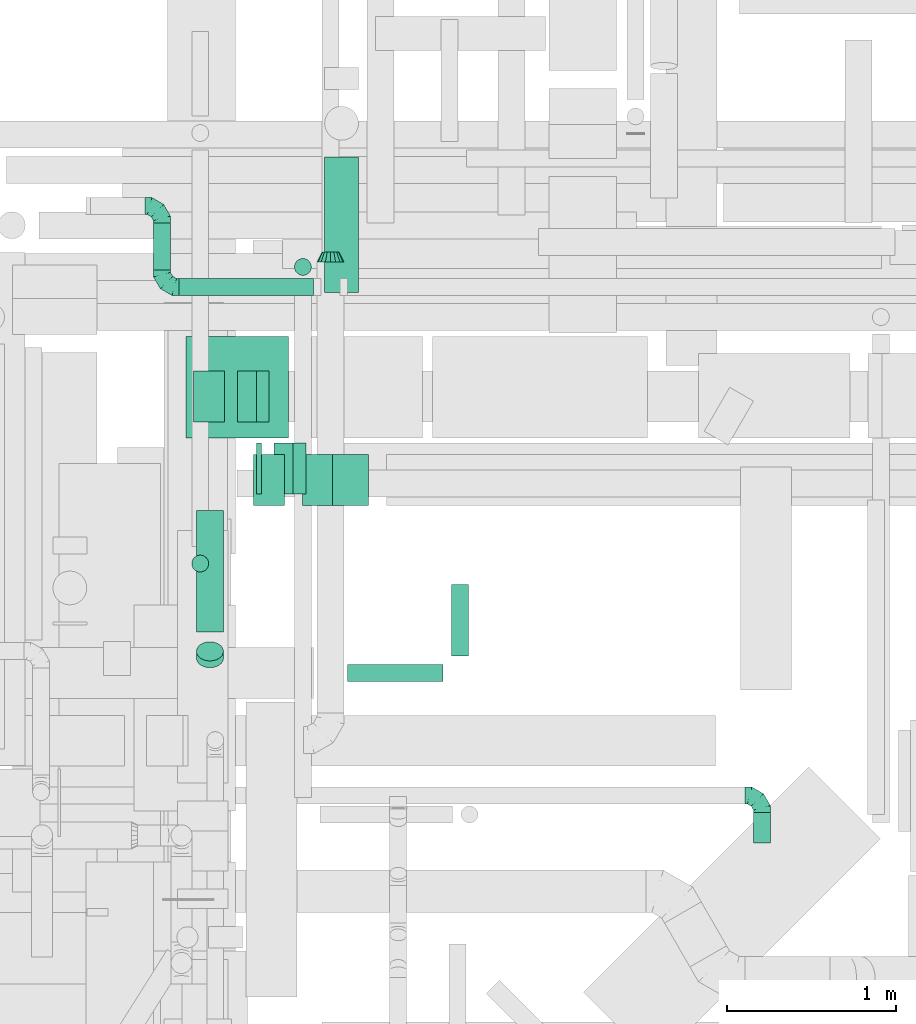
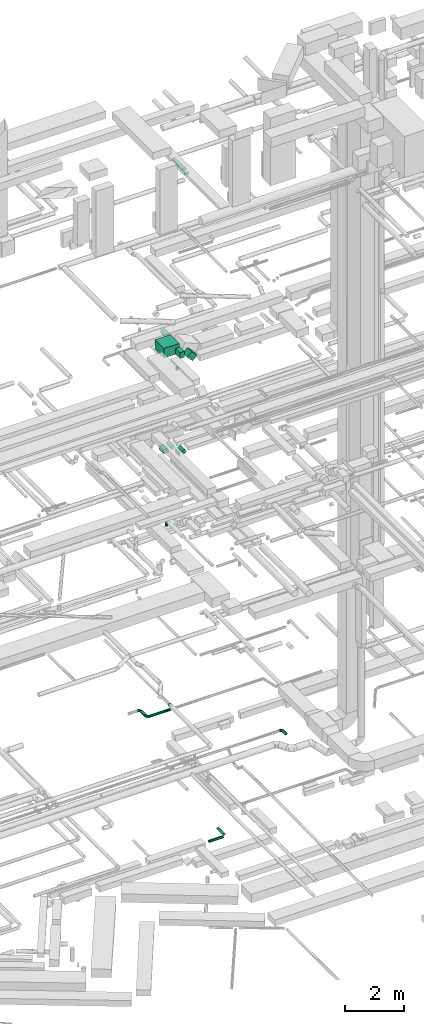
# One storey, part 112 of 337: 17 flow segments, 4 flow fittings.
"""IFC2X3 building model written with IfcOpenShell, lengths in millimetres."""

from ifc_helpers import new_model, entity, si_unit, converted_unit, derived_unit, direction, frame, frame_2d, origin, origin_2d_with_axis, place, context, subcontext, project, spatial, rectangle, circle, extrude, faceted_brep, source, transform, mapped, material, type_object, type_shapes, element, save


model = new_model("IFC2X3")

# Units and contexts
model_context = context("Model", 3, precision=0.01, world=origin(), true_north=direction((6.12303176911189e-17, 1.0)))
body_context = subcontext(model_context, "Body", "Model", "MODEL_VIEW")
ifc_project = project(units=[si_unit("LENGTHUNIT", "METRE", prefix="MILLI"), si_unit("AREAUNIT", "SQUARE_METRE"), si_unit("VOLUMEUNIT", "CUBIC_METRE"), converted_unit("PLANEANGLEUNIT", "DEGREE", entity("IfcRatioMeasure", 0.0174532925199433), si_unit("PLANEANGLEUNIT", "RADIAN"), dimensions=[0, 0, 0, 0, 0, 0, 0]), si_unit("MASSUNIT", "GRAM", prefix="KILO"), derived_unit("MASSDENSITYUNIT", [(si_unit("MASSUNIT", "GRAM", prefix="KILO"), 1), (si_unit("LENGTHUNIT", "METRE"), -3)]), derived_unit("MOMENTOFINERTIAUNIT", [(si_unit("LENGTHUNIT", "METRE"), 4)]), si_unit("TIMEUNIT", "SECOND"), si_unit("FREQUENCYUNIT", "HERTZ"), si_unit("THERMODYNAMICTEMPERATUREUNIT", "DEGREE_CELSIUS"), derived_unit("THERMALTRANSMITTANCEUNIT", [(si_unit("MASSUNIT", "GRAM", prefix="KILO"), 1), (si_unit("THERMODYNAMICTEMPERATUREUNIT", "KELVIN"), -1), (si_unit("TIMEUNIT", "SECOND"), -3)]), derived_unit("VOLUMETRICFLOWRATEUNIT", [(si_unit("LENGTHUNIT", "METRE"), 3), (si_unit("TIMEUNIT", "SECOND"), -1)]), derived_unit("MASSFLOWRATEUNIT", [(si_unit("MASSUNIT", "GRAM", prefix="KILO"), 1), (si_unit("TIMEUNIT", "SECOND"), -1)]), derived_unit("ROTATIONALFREQUENCYUNIT", [(si_unit("TIMEUNIT", "SECOND"), -1)]), si_unit("ELECTRICCURRENTUNIT", "AMPERE"), si_unit("ELECTRICVOLTAGEUNIT", "VOLT"), si_unit("POWERUNIT", "WATT"), si_unit("FORCEUNIT", "NEWTON", prefix="KILO"), si_unit("ILLUMINANCEUNIT", "LUX"), si_unit("LUMINOUSFLUXUNIT", "LUMEN"), si_unit("LUMINOUSINTENSITYUNIT", "CANDELA"), derived_unit("USERDEFINED", [(si_unit("MASSUNIT", "GRAM", prefix="KILO"), -1), (si_unit("LENGTHUNIT", "METRE"), -2), (si_unit("TIMEUNIT", "SECOND"), 3), (si_unit("LUMINOUSFLUXUNIT", "LUMEN"), 1)]), derived_unit("LINEARVELOCITYUNIT", [(si_unit("LENGTHUNIT", "METRE"), 1), (si_unit("TIMEUNIT", "SECOND"), -1)]), si_unit("PRESSUREUNIT", "PASCAL"), derived_unit("USERDEFINED", [(si_unit("LENGTHUNIT", "METRE"), -2), (si_unit("MASSUNIT", "GRAM", prefix="KILO"), 1), (si_unit("TIMEUNIT", "SECOND"), -2)]), derived_unit("LINEARFORCEUNIT", [(si_unit("MASSUNIT", "GRAM", prefix="KILO"), 1), (si_unit("LENGTHUNIT", "METRE"), 1), (si_unit("TIMEUNIT", "SECOND"), -2), (si_unit("LENGTHUNIT", "METRE"), -1)]), derived_unit("PLANARFORCEUNIT", [(si_unit("MASSUNIT", "GRAM", prefix="KILO"), 1), (si_unit("LENGTHUNIT", "METRE"), 1), (si_unit("TIMEUNIT", "SECOND"), -2), (si_unit("LENGTHUNIT", "METRE"), -2)])], contexts=[model_context])

# Site, building, storey
site_placement = place(None, origin())
site = spatial("IfcSite", under=ifc_project, at=site_placement, CompositionType="ELEMENT")
building_placement = place(site_placement, origin())
building = spatial("IfcBuilding", under=site, at=building_placement, CompositionType="ELEMENT")
storey_placement = place(building_placement, origin())
storey = spatial("IfcBuildingStorey", under=building, at=storey_placement, CompositionType="ELEMENT", Elevation=0.0)

# Flow segments
duct_segment_type_1 = type_object("IfcDuctSegmentType", PredefinedType="NOTDEFINED")
flow_segment_1_placement = place(storey_placement, frame((18449.48, 14422.9, 18950.0)))
element("IfcFlowSegment", 1, at=flow_segment_1_placement, inside=storey, type_object=duct_segment_type_1, context=body_context, shape_type="SweptSolid", body=[
    extrude(rectangle(XDim=606.778443805335, YDim=600.0, at=origin_2d_with_axis()), frame((303.39, 300.0, 0.0)), (0.0, 0.0, 1.0), 400.0),
])
flow_segment_2_placement = place(storey_placement, frame((18849.92, 14025.53, 19025.0)))
element("IfcFlowSegment", 2, at=flow_segment_2_placement, inside=storey, type_object=duct_segment_type_1, context=body_context, shape_type="SweptSolid", body=[
    extrude(rectangle(XDim=183.871270347418, YDim=300.000000000001, at=origin_2d_with_axis()), frame((91.94, 150.0, 0.0)), (0.0, 0.0, 1.0), 249.999999999999),
])
flow_segment_3_placement = place(storey_placement, frame((19139.86, 14025.53, 18767.16)))
element("IfcFlowSegment", 3, at=flow_segment_3_placement, inside=storey, type_object=duct_segment_type_1, context=body_context, shape_type="SweptSolid", body=[
    extrude(rectangle(XDim=250.000000000003, YDim=300.000000000001, at=origin_2d_with_axis()), frame((302.3, 150.0, 88.39), z_axis=(-0.707106781186509, 0.0, 0.707106781186587), x_axis=(0.707106781186587, 0.0, 0.707106781186509)), (0.0, 0.0, 1.0), 302.512626584715),
])
flow_segment_4_placement = place(storey_placement, frame((18494.75, 14518.91, 14925.0)))
element("IfcFlowSegment", 4, at=flow_segment_4_placement, inside=storey, type_object=duct_segment_type_1, context=body_context, shape_type="SweptSolid", body=[
    extrude(rectangle(XDim=184.695514085697, YDim=299.999999999999, at=origin_2d_with_axis()), frame((92.35, 150.0, 0.0)), (0.0, 0.0, 1.0), 150.000000000001),
])
flow_segment_5_placement = place(storey_placement, frame((18754.45, 14518.91, 14965.19)))
element("IfcFlowSegment", 5, at=flow_segment_5_placement, inside=storey, type_object=duct_segment_type_1, context=body_context, shape_type="SweptSolid", body=[
    extrude(rectangle(XDim=150.0, YDim=129.422872747523, at=frame_2d((0.0, 0.0), x_axis=(0.0, 1.0))), frame((93.54, 0.0, 97.31), z_axis=(0.0, 1.0, 0.0), x_axis=(0.866025410712589, 0.0, 0.499999988000091)), (0.0, 0.0, 1.0), 300.000000000001),
])
flow_segment_6_placement = place(storey_placement, frame((18866.63, 14093.91, 14925.0)))
element("IfcFlowSegment", 6, at=flow_segment_6_placement, inside=storey, type_object=duct_segment_type_1, context=body_context, shape_type="SweptSolid", body=[
    extrude(rectangle(XDim=30.4263240360212, YDim=300.000000000001, at=origin_2d_with_axis()), frame((15.21, 150.0, 0.0), z_axis=(0.0, 0.0, 1.0), x_axis=(-1.0, 0.0, 0.0)), (0.0, 0.0, 1.0), 150.000000000001),
])
flow_segment_7_placement = place(storey_placement, frame((18972.06, 14093.91, 14965.19)))
element("IfcFlowSegment", 7, at=flow_segment_7_placement, inside=storey, type_object=duct_segment_type_1, context=body_context, shape_type="SweptSolid", body=[
    extrude(rectangle(XDim=149.999999999999, YDim=129.422872747541, at=frame_2d((0.0, 0.0), x_axis=(0.0, 1.0))), frame((93.54, 0.0, 97.31), z_axis=(0.0, 1.0, 0.0), x_axis=(-0.866025410712638, 0.0, -0.499999988000007)), (0.0, 0.0, 1.0), 300.000000000001),
])
duct_segment_type_2 = type_object("IfcDuctSegmentType", PredefinedType="NOTDEFINED")
flow_segment_8_placement = place(storey_placement, frame((19405.55, 12982.48, -601.6)))
element("IfcFlowSegment", 8, at=flow_segment_8_placement, inside=storey, type_object=duct_segment_type_2, context=body_context, shape_type="SweptSolid", body=[
    extrude(circle(Radius=50.0, at=origin_2d_with_axis()), frame((0.0, 51.6, 51.6), z_axis=(1.0, 0.0, 0.0), x_axis=(0.0, -1.0, 0.0)), (0.0, 0.0, 1.0), 563.528786616429),
])
flow_segment_9_placement = place(storey_placement, frame((20017.48, 13134.08, -601.6)))
element("IfcFlowSegment", 9, at=flow_segment_9_placement, inside=storey, type_object=duct_segment_type_2, context=body_context, shape_type="SweptSolid", body=[
    extrude(circle(Radius=50.0, at=origin_2d_with_axis()), frame((51.6, 0.0, 51.6), z_axis=(0.0, 1.0, 0.0), x_axis=(1.0, 0.0, 0.0)), (0.0, 0.0, 1.0), 425.000000000081),
])
flow_segment_10_placement = place(storey_placement, frame((19089.97, 15383.25, 11170.0)))
element("IfcFlowSegment", 10, at=flow_segment_10_placement, inside=storey, type_object=duct_segment_type_2, context=body_context, shape_type="SweptSolid", body=[
    extrude(circle(Radius=50.0, at=origin_2d_with_axis()), frame((51.6, 51.6, 0.0), z_axis=(0.0, 0.0, 1.0), x_axis=(-1.0, 0.0, 0.0)), (0.0, 0.0, 1.0), 129.999999999992),
])
flow_segment_11_placement = place(storey_placement, frame((18408.44, 15264.53, 3548.4)))
element("IfcFlowSegment", 11, at=flow_segment_11_placement, inside=storey, type_object=duct_segment_type_2, context=body_context, shape_type="SweptSolid", body=[
    extrude(circle(Radius=50.0, at=origin_2d_with_axis()), frame((0.0, 51.6, 51.6), z_axis=(1.0, 0.0, 0.0), x_axis=(0.0, -1.0, 0.0)), (0.0, 0.0, 1.0), 796.250000000051),
])
flow_segment_12_placement = place(storey_placement, frame((18256.85, 15416.13, 3548.4)))
element("IfcFlowSegment", 12, at=flow_segment_12_placement, inside=storey, type_object=duct_segment_type_2, context=body_context, shape_type="SweptSolid", body=[
    extrude(circle(Radius=50.0, at=origin_2d_with_axis()), frame((51.6, 0.0, 51.6), z_axis=(0.0, 1.0, 0.0), x_axis=(1.0, 0.0, 0.0)), (0.0, 0.0, 1.0), 278.749999999971),
])
flow_segment_13_placement = place(storey_placement, frame((18482.93, 13629.62, 18900.0)))
element("IfcFlowSegment", 13, at=flow_segment_13_placement, inside=storey, type_object=duct_segment_type_2, context=body_context, shape_type="SweptSolid", body=[
    extrude(circle(Radius=50.0, at=origin_2d_with_axis()), frame((51.6, 51.6, 0.0), z_axis=(0.0, 0.0, 1.0), x_axis=(-1.0, 0.0, 0.0)), (0.0, 0.0, 1.0), 104.999999999976),
])
flow_segment_14_placement = place(storey_placement, frame((19268.68, 15283.92, 18653.4)))
element("IfcFlowSegment", 14, at=flow_segment_14_placement, inside=storey, type_object=duct_segment_type_2, context=body_context, shape_type="SweptSolid", body=[
    extrude(circle(Radius=100.0, at=origin_2d_with_axis()), frame((101.6, 0.0, 101.6), z_axis=(0.0, 1.0, 0.0), x_axis=(-1.0, 0.0, 0.0)), (0.0, 0.0, 1.0), 800.000000000009),
])
flow_segment_15_placement = place(storey_placement, frame((18510.14, 13064.23, 27254.97)))
element("IfcFlowSegment", 15, at=flow_segment_15_placement, inside=storey, type_object=duct_segment_type_2, context=body_context, shape_type="SweptSolid", body=[
    extrude(circle(Radius=80.0, at=origin_2d_with_axis()), frame((81.6, 58.16, 58.16), z_axis=(0.0, 0.707106781186551, 0.707106781186544), x_axis=(1.0, 0.0, 0.0)), (0.0, 0.0, 1.0), 56.5685424949942),
])
flow_segment_16_placement = place(storey_placement, frame((18510.14, 13275.54, 27318.4)))
element("IfcFlowSegment", 16, at=flow_segment_16_placement, inside=storey, type_object=duct_segment_type_2, context=body_context, shape_type="SweptSolid", body=[
    extrude(circle(Radius=80.0, at=origin_2d_with_axis()), frame((81.6, 0.0, 81.6), z_axis=(0.0, 1.0, 0.0), x_axis=(-1.0, 0.0, 0.0)), (0.0, 0.0, 1.0), 719.425830020302),
])
flow_segment_17_placement = place(storey_placement, frame((21803.57, 12030.36, 3598.4)))
element("IfcFlowSegment", 17, at=flow_segment_17_placement, inside=storey, type_object=duct_segment_type_2, context=body_context, shape_type="SweptSolid", body=[
    extrude(circle(Radius=50.0, at=origin_2d_with_axis()), frame((51.6, 0.0, 51.6), z_axis=(0.0, 1.0, 0.0), x_axis=(-1.0, 0.0, 0.0)), (0.0, 0.0, 1.0), 179.999999999994),
])

# Flow fittings
ifc_material = material()
duct_fitting_type_1 = type_object("IfcDuctFittingType", PredefinedType="NOTDEFINED", material=ifc_material)
shared_shape_1 = source(origin(), body_context, "Body", "Brep", [
    faceted_brep([(-100.0, 0.0, -50.0), (-100.0, -12.94, -48.3), (-100.0, -25.0, -43.3), (-100.0, -35.36, -35.36), (-100.0, -43.3, -25.0), (-100.0, -48.3, -12.94), (-100.0, -50.0, 0.0), (-100.0, -48.3, 12.94), (-100.0, -43.3, 25.0), (-100.0, -35.36, 35.36), (-100.0, -25.0, 43.3), (-100.0, -12.94, 48.3), (-100.0, 0.0, 50.0), (-100.0, 12.94, 48.3), (-100.0, 25.0, 43.3), (-100.0, 35.36, 35.36), (-100.0, 43.3, 25.0), (-100.0, 48.3, 12.94), (-100.0, 50.0, 0.0), (-100.0, 48.3, -12.94), (-100.0, 43.3, -25.0), (-100.0, 35.36, -35.36), (-100.0, 25.0, -43.3), (-100.0, 12.94, -48.3), (-76.67, 12.94, 48.3), (-79.9, 25.0, 43.3), (-73.21, 0.0, 50.0), (-82.68, 35.36, 35.36), (-86.15, 48.3, 12.94), (-86.6, 50.0, 0.0), (-84.81, 43.3, 25.0), (-84.81, 43.3, -25.0), (-82.68, 35.36, -35.36), (-86.15, 48.3, -12.94), (-76.67, 12.94, -48.3), (-73.21, 0.0, -50.0), (-79.9, 25.0, -43.3), (-69.74, -12.94, -48.3), (-66.51, -25.0, -43.3), (-63.73, -35.36, -35.36), (-61.6, -43.3, -25.0), (-60.26, -48.3, -12.94), (-59.81, -50.0, 0.0), (-60.26, -48.3, 12.94), (-61.6, -43.3, 25.0), (-63.73, -35.36, 35.36), (-66.51, -25.0, 43.3), (-69.74, -12.94, 48.3), (-36.27, 36.27, 48.3), (-45.1, 45.1, 43.3), (-26.79, 26.79, 50.0), (-52.68, 52.68, 35.36), (-58.49, 58.49, 25.0), (-62.15, 62.15, 12.94), (-63.4, 63.4, 0.0), (-62.15, 62.15, -12.94), (-58.49, 58.49, -25.0), (-52.68, 52.68, -35.36), (-36.27, 36.27, -48.3), (-26.79, 26.79, -50.0), (-45.1, 45.1, -43.3), (-17.32, 17.32, -48.3), (-8.49, 8.49, -43.3), (-0.91, 0.91, -35.36), (4.9, -4.9, -25.0), (8.56, -8.56, -12.94), (9.81, -9.81, 0.0), (8.56, -8.56, 12.94), (4.9, -4.9, 25.0), (-0.91, 0.91, 35.36), (-8.49, 8.49, 43.3), (-17.32, 17.32, 48.3), (-12.94, 76.67, 48.3), (-25.0, 79.9, 43.3), (0.0, 73.21, 50.0), (-35.36, 82.68, 35.36), (-43.3, 84.81, 25.0), (-48.3, 86.15, 12.94), (-50.0, 86.6, 0.0), (-48.3, 86.15, -12.94), (-43.3, 84.81, -25.0), (-35.36, 82.68, -35.36), (-12.94, 76.67, -48.3), (0.0, 73.21, -50.0), (-25.0, 79.9, -43.3), (12.94, 69.74, -48.3), (25.0, 66.51, -43.3), (35.36, 63.73, -35.36), (43.3, 61.6, -25.0), (48.3, 60.26, -12.94), (50.0, 59.81, 0.0), (48.3, 60.26, 12.94), (43.3, 61.6, 25.0), (35.36, 63.73, 35.36), (25.0, 66.51, 43.3), (12.94, 69.74, 48.3), (-12.94, 100.0, -48.3), (-25.0, 100.0, -43.3), (-35.36, 100.0, -35.36), (-43.3, 100.0, -25.0), (-48.3, 100.0, -12.94), (-50.0, 100.0, 0.0), (-48.3, 100.0, 12.94), (-43.3, 100.0, 25.0), (-35.36, 100.0, 35.36), (-25.0, 100.0, 43.3), (-12.94, 100.0, 48.3), (0.0, 100.0, 50.0), (12.94, 100.0, 48.3), (25.0, 100.0, 43.3), (35.36, 100.0, 35.36), (43.3, 100.0, 25.0), (48.3, 100.0, 12.94), (50.0, 100.0, 0.0), (48.3, 100.0, -12.94), (43.3, 100.0, -25.0), (35.36, 100.0, -35.36), (25.0, 100.0, -43.3), (12.94, 100.0, -48.3), (0.0, 100.0, -50.0)], [[[0, 1, 2, 3, 4, 5, 6, 7, 8, 9, 10, 11, 12, 13, 14, 15, 16, 17, 18, 19, 20, 21, 22, 23]], [[24, 25, 14, 13]], [[26, 24, 13, 12]], [[14, 25, 27, 15]], [[28, 29, 18, 17]], [[30, 28, 17, 16]], [[15, 27, 30, 16]], [[20, 31, 32, 21]], [[33, 31, 20, 19]], [[18, 29, 33, 19]], [[34, 35, 0, 23]], [[36, 34, 23, 22]], [[32, 36, 22, 21]], [[2, 1, 37, 38]], [[3, 2, 38, 39]], [[0, 35, 37, 1]], [[5, 4, 40, 41]], [[6, 5, 41, 42]], [[3, 39, 40, 4]], [[6, 42, 43, 7]], [[7, 43, 44, 8]], [[8, 44, 45, 9]], [[10, 46, 47, 11]], [[11, 47, 26, 12]], [[10, 9, 45, 46]], [[48, 49, 25, 24]], [[50, 48, 24, 26]], [[27, 25, 49, 51]], [[52, 53, 28, 30]], [[51, 52, 30, 27]], [[29, 28, 53, 54]], [[55, 56, 31, 33]], [[54, 55, 33, 29]], [[57, 32, 31, 56]], [[58, 59, 35, 34]], [[60, 58, 34, 36]], [[57, 60, 36, 32]], [[37, 35, 59, 61]], [[38, 37, 61, 62]], [[39, 38, 62, 63]], [[41, 40, 64, 65]], [[42, 41, 65, 66]], [[63, 64, 40, 39]], [[43, 42, 66, 67]], [[44, 43, 67, 68]], [[68, 69, 45, 44]], [[46, 45, 69, 70]], [[47, 46, 70, 71]], [[26, 47, 71, 50]], [[72, 73, 49, 48]], [[74, 72, 48, 50]], [[51, 49, 73, 75]], [[76, 77, 53, 52]], [[75, 76, 52, 51]], [[54, 53, 77, 78]], [[79, 80, 56, 55]], [[78, 79, 55, 54]], [[81, 57, 56, 80]], [[82, 83, 59, 58]], [[84, 82, 58, 60]], [[81, 84, 60, 57]], [[61, 59, 83, 85]], [[62, 61, 85, 86]], [[63, 62, 86, 87]], [[65, 64, 88, 89]], [[66, 65, 89, 90]], [[87, 88, 64, 63]], [[67, 66, 90, 91]], [[68, 67, 91, 92]], [[92, 93, 69, 68]], [[70, 69, 93, 94]], [[71, 70, 94, 95]], [[50, 71, 95, 74]], [[96, 97, 98, 99, 100, 101, 102, 103, 104, 105, 106, 107, 108, 109, 110, 111, 112, 113, 114, 115, 116, 117, 118, 119]], [[72, 74, 107, 106]], [[73, 72, 106, 105]], [[75, 73, 105, 104]], [[77, 76, 103, 102]], [[78, 77, 102, 101]], [[75, 104, 103, 76]], [[78, 101, 100, 79]], [[79, 100, 99, 80]], [[80, 99, 98, 81]], [[96, 119, 83, 82]], [[97, 96, 82, 84]], [[84, 81, 98, 97]], [[83, 119, 118, 85]], [[85, 118, 117, 86]], [[86, 117, 116, 87]], [[88, 115, 114, 89]], [[89, 114, 113, 90]], [[87, 116, 115, 88]], [[91, 90, 113, 112]], [[92, 91, 112, 111]], [[93, 92, 111, 110]], [[95, 94, 109, 108]], [[74, 95, 108, 107]], [[110, 109, 94, 93]]]),
])
type_shapes(duct_fitting_type_1, [shared_shape_1])
for number, where, z_axis, x_axis in (
    (18, (18308.44, 15794.88, 3600.0), (0.0, 0.0, 1.0), (0.0, 1.0, 0.0)),
    (19, (18308.44, 15316.13, 3600.0), (0.0, 0.0, 1.0), (0.0, -1.0, 0.0)),
    (20, (21855.16, 12310.36, 3650.0), (0.0, 0.0, 1.0), (0.0, 1.0, 0.0)),
):
    element("IfcFlowFitting", number, at=place(storey_placement, frame(where, z_axis=z_axis, x_axis=x_axis)), inside=storey, type_object=duct_fitting_type_1, material=ifc_material, context=body_context, shape_type="MappedRepresentation", body=[
        mapped(shared_shape_1, transform((0.0, 0.0, 0.0), scale=1.0)),
    ])
duct_fitting_type_2 = type_object("IfcDuctFittingType", PredefinedType="NOTDEFINED", material=ifc_material)
shared_shape_2 = source(origin(), body_context, "Body", "Brep", [
    faceted_brep([(60.0, -46.19, 19.13), (60.0, -48.1, 9.57), (60.0, -50.0, 0.0), (60.0, -48.1, -9.57), (60.0, -46.19, -19.13), (60.0, -40.77, -27.24), (60.0, -35.36, -35.36), (60.0, -27.24, -40.77), (60.0, -19.13, -46.19), (60.0, -9.57, -48.1), (60.0, 0.0, -50.0), (60.0, 9.57, -48.1), (60.0, 19.13, -46.19), (60.0, 27.24, -40.77), (60.0, 35.36, -35.36), (60.0, 40.77, -27.24), (60.0, 46.19, -19.13), (60.0, 48.1, -9.57), (60.0, 50.0, 0.0), (60.0, 48.1, 9.57), (60.0, 46.19, 19.13), (60.0, 40.77, 27.24), (60.0, 35.36, 35.36), (60.0, 27.24, 40.77), (60.0, 19.13, 46.19), (60.0, 9.57, 48.1), (60.0, 0.0, 50.0), (60.0, -9.57, 48.1), (60.0, -19.13, 46.19), (60.0, -27.24, 40.77), (60.0, -35.36, 35.36), (60.0, -40.77, 27.24), (0.0, -80.0, 0.0), (0.0, -77.16, 14.27), (0.0, -73.91, 30.61), (0.0, -65.24, 43.59), (0.0, -56.57, 56.57), (0.0, -43.59, 65.24), (0.0, -30.61, 73.91), (0.0, -15.31, 76.96), (0.0, 0.0, 80.0), (0.0, 14.27, 77.16), (0.0, 30.61, 73.91), (0.0, 43.59, 65.24), (0.0, 56.57, 56.57), (0.0, 65.24, 43.59), (0.0, 73.91, 30.61), (0.0, 76.96, 15.31), (0.0, 80.0, 0.0), (0.0, 77.16, -14.27), (0.0, 73.91, -30.61), (0.0, 65.24, -43.59), (0.0, 56.57, -56.57), (0.0, 43.59, -65.24), (0.0, 30.61, -73.91), (0.0, 15.31, -76.96), (0.0, 0.0, -80.0), (0.0, -14.27, -77.16), (0.0, -30.61, -73.91), (0.0, -43.59, -65.24), (0.0, -56.57, -56.57), (0.0, -65.24, -43.59), (0.0, -73.91, -30.61), (0.0, -76.96, -15.31)], [[[0, 1, 2, 3, 4, 5, 6, 7, 8, 9, 10, 11, 12, 13, 14, 15, 16, 17, 18, 19, 20, 21, 22, 23, 24, 25, 26, 27, 28, 29, 30, 31]], [[32, 33, 34, 35, 36, 37, 38, 39, 40, 41, 42, 43, 44, 45, 46, 47, 48, 49, 50, 51, 52, 53, 54, 55, 56, 57, 58, 59, 60, 61, 62, 63]], [[42, 41, 40, 26, 25, 24]], [[43, 42, 24, 23, 22, 44]], [[20, 46, 45, 44, 22, 21]], [[18, 48, 47, 46, 20, 19]], [[34, 33, 32, 2, 1, 0]], [[35, 34, 0, 31, 30, 36]], [[28, 38, 37, 36, 30, 29]], [[26, 40, 39, 38, 28, 27]], [[58, 57, 56, 10, 9, 8]], [[59, 58, 8, 7, 6, 60]], [[4, 62, 61, 60, 6, 5]], [[2, 32, 63, 62, 4, 3]], [[50, 49, 48, 18, 17, 16]], [[51, 50, 16, 15, 14, 52]], [[12, 54, 53, 52, 14, 13]], [[10, 56, 55, 54, 12, 11]]]),
])
type_shapes(duct_fitting_type_2, [shared_shape_2])
flow_fitting_placement = place(storey_placement, frame((19304.69, 15463.58, 3650.0), z_axis=(0.0, 0.0, 1.0), x_axis=(0.0, 1.0, 0.0)))
element("IfcFlowFitting", 21, at=flow_fitting_placement, inside=storey, type_object=duct_fitting_type_2, material=ifc_material, context=body_context, shape_type="MappedRepresentation", body=[
    mapped(shared_shape_2, transform((0.0, 0.0, 0.0), scale=1.0)),
])

save(model, "model.ifc")
